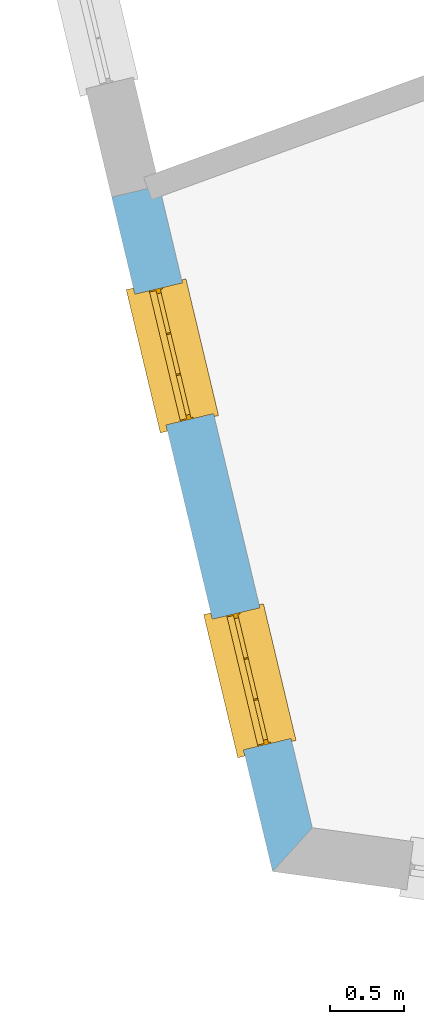
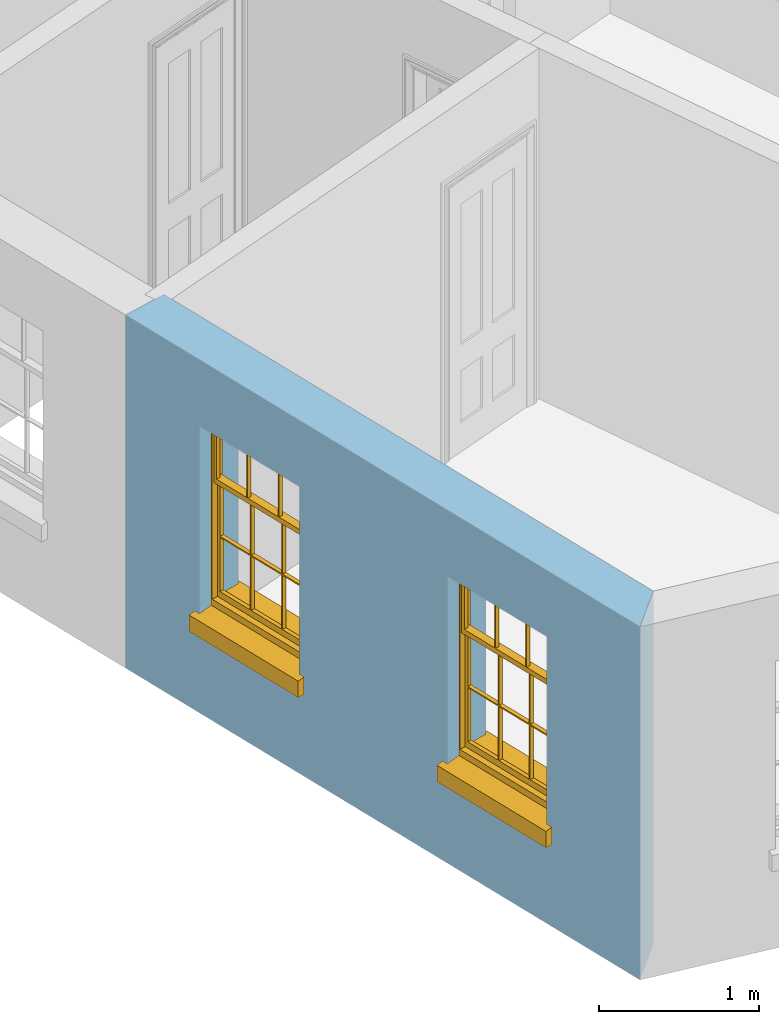
# One storey, part 2 of 12: 2 windows, 2 openings, plus 1 element that does not belong to this part.
"""IFC2X3 building model written with IfcOpenShell, lengths in metres."""

from ifc_helpers import new_model, si_unit, frame, origin, place, context, subcontext, project, spatial, polyline, outline, extrude, faceted_brep, material, layer, layer_set, layer_usage, element, fill, save


model = new_model("IFC2X3")

# Units and contexts
model_context = context("Model", 3, world=origin())
body_context = subcontext(model_context, "Body", "Model", "MODEL_VIEW")
ifc_project = project(units=[si_unit("PLANEANGLEUNIT", "RADIAN"), si_unit("MASSUNIT", "GRAM", prefix="KILO"), si_unit("FORCEUNIT", "NEWTON", prefix="KILO"), si_unit("LENGTHUNIT", "METRE")], contexts=[model_context])

# Site, building, storey
site_placement = place(None, origin())
site = spatial("IfcSite", under=ifc_project, at=site_placement, CompositionType="ELEMENT")
building_placement = place(None, origin())
building = spatial("IfcBuilding", under=site, at=building_placement, Name="Building plot-12", CompositionType="ELEMENT")
storey_placement = place(None, frame((0.0, 0.0, 6.45)))
storey = spatial("IfcBuildingStorey", under=building, at=storey_placement, Name="Floor 1", CompositionType="ELEMENT", Elevation=6.45)

# Wall, openings, windows
ifc_material = material(Name="Masonry")
ifc_layer = layer(ifc_material, 0.33, ventilated=False)
ifc_layer_set = layer_set([ifc_layer], Name="My Wall")
ifc_layer_usage = layer_usage(ifc_layer_set, "AXIS2", "NEGATIVE", 0.08)
wall_placement = place(storey_placement, origin())
wall = element("IfcWallStandardCase", 1, at=wall_placement, inside=storey, material=ifc_layer_usage, Name="exterior", context=body_context, shape_type="SweptSolid", body=[
    extrude(outline(polyline([(54.7536599454522, 36.2256595733621), (54.4326600181389, 36.1491151636064), (55.519891283054, 31.5896553921575), (55.7885191142734, 31.8858296755126), (54.7536599454522, 36.2256595733621)])), origin(), (0.0, 0.0, 1.0), 2.7),
])
opening_1_placement = place(storey_placement, frame((0.0, 0.0, 0.75)))
opening_1 = element("IfcOpeningElement", 2, at=opening_1_placement, cuts=wall, Name="Opening", ObjectType="Opening", context=body_context, shape_type="SweptSolid", body=[
    extrude(outline(polyline([(54.5890103724139, 35.4934375965852), (54.8000873811343, 34.6082559788424), (55.1210873084476, 34.6848003885981), (54.9100102997273, 35.5699820063409), (54.5890103724139, 35.4934375965852)])), origin(), (0.0, 0.0, 1.0), 1.445),
])
opening_2_placement = place(storey_placement, frame((0.0, 0.0, 0.75)))
opening_2 = element("IfcOpeningElement", 3, at=opening_2_placement, cuts=wall, Name="Opening", ObjectType="Opening", context=body_context, shape_type="SweptSolid", body=[
    extrude(outline(polyline([(55.1127880896844, 33.2969008447999), (55.3238650984048, 32.4117192270571), (55.6448650257181, 32.4882636368128), (55.4337880169978, 33.3734452545556), (55.1127880896844, 33.2969008447999)])), origin(), (0.0, 0.0, 1.0), 1.445),
])
window_1_placement = place(storey_placement, frame((54.8321921355301, 35.551425785794, 0.75), z_axis=(0.0, 0.0, 1.0), x_axis=(0.211077008720331, -0.885181617742752, 0.0)))
window_1 = element("IfcWindow", 4, at=window_1_placement, inside=storey, Name="living outside window", OverallHeight=1.445, OverallWidth=0.91, context=body_context, shape_type="Brep", held_by="IfcProductRepresentation", body=[
    faceted_brep([(0.876875, -0.105, 0.999097), (0.876875, -0.105, 1.411875), (0.9, -0.105, 1.435), (0.033125, -0.105, 1.411875), (0.033125, -0.105, 0.999097), (0.01, -0.105, 1.435), (0.033125, -0.135, 1.411875), (0.01, -0.135, 1.435), (0.033125, -0.135, 0.999097), (0.876875, -0.135, 1.411875), (0.876875, -0.135, 0.999097), (0.9, -0.135, 1.435), (0.033125, -0.105, 0.960972), (0.01, -0.105, 0.960972), (0.033125, -0.105, 0.548195), (0.876875, -0.105, 0.960972), (0.876875, -0.105, 0.548195), (0.9, -0.105, 0.960972), (0.876875, -0.105, 0.538195), (0.876875, -0.105, 0.125417), (0.9, -0.105, 0.077167), (0.033125, -0.105, 0.125417), (0.033125, -0.105, 0.538195), (0.01, -0.105, 0.077167), (0.9, -0.135, 0.960972), (0.01, -0.135, 0.960972), (-0.0425, -0.25, 0.01), (-0.0425, -0.3, 0.001667), (0.0, -0.25, 0.01), (0.9525, -0.25, 0.01), (0.91, -0.25, 0.01), (0.9525, -0.3, 0.001667), (-0.02, 0.08, 0.077167), (0.0, 0.08, 0.077167), (-0.02, 0.11, 0.077167), (0.0, -0.06, 0.077167), (0.01, -0.06, 0.077167), (0.91, -0.06, 0.077167), (0.91, 0.08, 0.077167), (0.9, -0.06, 0.077167), (0.93, 0.08, 0.077167), (0.93, 0.11, 0.077167), (0.01, -0.105, 0.999097), (0.01, -0.075, 0.999097), (0.9, -0.105, 0.999097), (0.9, -0.075, 0.999097), (0.876875, -0.075, 0.125417), (0.876875, -0.075, 0.538195), (0.9, -0.075, 0.077167), (0.876875, -0.075, 0.548195), (0.876875, -0.075, 0.960972), (0.033125, -0.075, 0.125417), (0.01, -0.075, 0.077167), (0.033125, -0.075, 0.538195), (0.033125, -0.075, 0.960972), (0.033125, -0.075, 0.548195), (-0.02, 0.08, 0.052167), (-0.02, 0.11, 0.052167), (0.93, 0.11, 0.052167), (0.93, 0.08, 0.052167), (0.91, 0.08, 0.052167), (0.0, 0.08, 0.052167), (0.91, -0.15, 0.026667), (0.0, -0.15, 0.026667), (-0.0425, -0.3, -0.123333), (0.9525, -0.3, -0.123333), (-0.0425, -0.25, -0.123333), (0.9525, -0.25, -0.123333), (0.01, -0.06, 1.435), (0.9, -0.06, 1.435), (0.0, -0.06, 1.445), (0.91, -0.06, 1.445), (0.01, -0.15, 0.077167), (0.9, -0.15, 0.077167), (0.592292, -0.105, 0.125417), (0.592292, -0.075, 0.125417), (0.317708, -0.075, 0.125417), (0.317708, -0.105, 0.125417), (0.592292, -0.105, 0.548195), (0.317708, -0.105, 0.548195), (0.317708, -0.105, 0.538195), (0.592292, -0.105, 0.538195), (0.592292, -0.075, 0.548195), (0.317708, -0.075, 0.548195), (0.602292, -0.075, 0.548195), (0.602292, -0.105, 0.548195), (0.317708, -0.075, 0.538195), (0.307708, -0.075, 0.125417), (0.307708, -0.075, 0.538195), (0.602292, -0.075, 0.538195), (0.602292, -0.075, 0.125417), (0.592292, -0.075, 0.538195), (0.307708, -0.075, 0.548195), (0.317708, -0.075, 0.960972), (0.307708, -0.075, 0.960972), (0.602292, -0.075, 0.960972), (0.592292, -0.075, 0.960972), (0.307708, -0.105, 0.538195), (0.307708, -0.105, 0.125417), (0.307708, -0.105, 0.548195), (0.307708, -0.105, 0.960972), (0.592292, -0.105, 0.960972), (0.317708, -0.105, 0.960972), (0.602292, -0.105, 0.960972), (0.602292, -0.105, 0.538195), (0.602292, -0.105, 0.125417), (0.317708, -0.135, 1.411875), (0.307708, -0.135, 1.411875), (0.307708, -0.135, 0.999097), (0.317708, -0.135, 0.999097), (0.602292, -0.135, 1.411875), (0.592292, -0.135, 1.411875), (0.592292, -0.135, 0.999097), (0.602292, -0.135, 0.999097), (0.317708, -0.105, 0.999097), (0.307708, -0.105, 0.999097), (0.307708, -0.105, 1.411875), (0.317708, -0.105, 1.411875), (0.602292, -0.105, 0.999097), (0.592292, -0.105, 0.999097), (0.592292, -0.105, 1.411875), (0.602292, -0.105, 1.411875), (0.91, -0.15, 1.445), (0.9, -0.15, 1.435), (0.01, -0.15, 1.435), (0.0, -0.15, 1.445), (0.91, -0.25, 0.0), (0.0, -0.25, 0.0), (0.91, 0.08, 0.0), (0.0, 0.08, 0.0)], [[[0, 1, 2]], [[3, 4, 5]], [[6, 7, 8]], [[9, 10, 11]], [[12, 13, 14]], [[15, 16, 17]], [[18, 19, 20]], [[21, 22, 23]], [[24, 15, 17]], [[13, 12, 25]], [[26, 27, 28]], [[29, 30, 31]], [[32, 33, 34]], [[35, 36, 33]], [[37, 38, 39]], [[40, 41, 38]], [[42, 4, 43]], [[44, 45, 0]], [[46, 47, 48]], [[49, 50, 45]], [[51, 52, 53]], [[54, 55, 43]], [[38, 33, 36, 39]], [[41, 34, 33, 38]], [[56, 32, 34, 57]], [[57, 34, 41, 58]], [[58, 41, 40, 59]], [[57, 58, 60, 61]], [[52, 48, 39, 36]], [[62, 63, 28, 30]], [[27, 31, 30, 28]], [[27, 64, 65, 31]], [[66, 67, 65, 64]], [[2, 5, 68, 69]], [[68, 70, 71, 69]], [[20, 23, 72, 73]], [[73, 72, 63, 62]], [[74, 75, 76, 77]], [[78, 79, 80, 81]], [[78, 82, 83, 79]], [[16, 49, 84, 85]], [[86, 76, 87, 88]], [[89, 90, 75, 91]], [[92, 88, 53, 55]], [[82, 91, 86, 83]], [[93, 83, 92, 94]], [[95, 84, 82, 96]], [[89, 84, 49, 47]], [[97, 88, 87, 98]], [[22, 53, 88, 97]], [[81, 91, 75, 74]], [[80, 86, 91, 81]], [[77, 76, 86, 80]], [[99, 92, 55, 14]], [[100, 94, 92, 99]], [[101, 96, 82, 78]], [[79, 83, 93, 102]], [[85, 84, 95, 103]], [[104, 89, 47, 18]], [[105, 90, 89, 104]], [[104, 18, 16, 85]], [[80, 97, 98, 77]], [[104, 81, 74, 105]], [[103, 101, 78, 85]], [[99, 14, 22, 97]], [[102, 100, 99, 79]], [[106, 107, 108, 109]], [[110, 111, 112, 113]], [[114, 115, 116, 117]], [[118, 119, 120, 121]], [[107, 116, 115, 108]], [[111, 120, 119, 112]], [[109, 114, 117, 106]], [[113, 118, 121, 110]], [[85, 78, 81, 104]], [[84, 89, 91, 82]], [[83, 86, 88, 92]], [[79, 99, 97, 80]], [[109, 112, 119, 114]], [[102, 93, 96, 101]], [[106, 117, 120, 111]], [[98, 87, 51, 21]], [[6, 3, 116, 107]], [[110, 121, 1, 9]], [[19, 46, 90, 105]], [[26, 66, 64, 27]], [[29, 31, 65, 67]], [[25, 24, 112, 109]], [[11, 7, 106, 111]], [[75, 48, 52, 76]], [[43, 45, 96, 93]], [[45, 43, 114, 119]], [[5, 2, 120, 117]], [[24, 25, 102, 101]], [[42, 5, 4]], [[2, 44, 0]], [[49, 45, 48, 47]], [[52, 43, 55, 53]], [[14, 13, 23, 22]], [[20, 17, 16, 18]], [[24, 11, 10]], [[25, 8, 7]], [[8, 4, 3, 6]], [[9, 1, 0, 10]], [[15, 50, 49, 16]], [[18, 47, 46, 19]], [[21, 51, 53, 22]], [[14, 55, 54, 12]], [[44, 2, 69, 45]], [[68, 5, 42, 43]], [[36, 35, 70, 68]], [[39, 69, 71, 37]], [[62, 122, 123, 73]], [[63, 72, 124, 125]], [[8, 108, 115, 4]], [[113, 10, 0, 118]], [[94, 100, 12, 54]], [[17, 20, 73, 24]], [[72, 23, 13, 25]], [[52, 36, 68, 43]], [[69, 39, 48, 45]], [[11, 24, 73, 123]], [[7, 124, 72, 25]], [[23, 77, 98]], [[98, 21, 23]], [[105, 74, 20]], [[20, 19, 105]], [[20, 74, 77, 23]], [[113, 112, 24]], [[24, 10, 113]], [[25, 109, 108]], [[108, 8, 25]], [[110, 9, 11]], [[11, 111, 110]], [[7, 6, 107]], [[107, 106, 7]], [[5, 117, 116]], [[116, 3, 5]], [[121, 120, 2]], [[2, 1, 121]], [[11, 123, 124, 7]], [[122, 125, 124, 123]], [[43, 93, 94]], [[94, 54, 43]], [[96, 45, 95]], [[50, 95, 45]], [[15, 103, 95, 50]], [[48, 75, 90]], [[90, 46, 48]], [[87, 76, 52]], [[52, 51, 87]], [[103, 15, 24]], [[24, 101, 103]], [[100, 102, 25]], [[25, 12, 100]], [[115, 114, 43]], [[43, 4, 115]], [[118, 0, 45]], [[45, 119, 118]], [[71, 70, 125, 122]], [[70, 35, 63, 125]], [[122, 62, 37, 71]], [[126, 67, 66, 127]], [[60, 58, 59]], [[38, 60, 59, 40]], [[61, 56, 57]], [[32, 56, 61, 33]], [[61, 60, 128, 129]], [[62, 60, 38, 37]], [[126, 128, 60, 62]], [[33, 61, 63, 35]], [[61, 129, 127, 63]], [[128, 126, 127, 129]], [[28, 127, 66, 26]], [[63, 127, 28]], [[29, 67, 126, 30]], [[30, 126, 62]]]),
])
fill(opening_1, window_1)
window_2_placement = place(storey_placement, frame((55.3559698528006, 33.3548890340087, 0.75), z_axis=(0.0, 0.0, 1.0), x_axis=(0.211077008720331, -0.885181617742752, 0.0)))
window_2 = element("IfcWindow", 5, at=window_2_placement, inside=storey, Name="living outside window", OverallHeight=1.445, OverallWidth=0.91, context=body_context, shape_type="Brep", held_by="IfcProductRepresentation", body=[
    faceted_brep([(0.876875, -0.105, 0.999097), (0.876875, -0.105, 1.411875), (0.9, -0.105, 1.435), (0.033125, -0.105, 1.411875), (0.033125, -0.105, 0.999097), (0.01, -0.105, 1.435), (0.033125, -0.135, 1.411875), (0.01, -0.135, 1.435), (0.033125, -0.135, 0.999097), (0.876875, -0.135, 1.411875), (0.876875, -0.135, 0.999097), (0.9, -0.135, 1.435), (0.033125, -0.105, 0.960972), (0.01, -0.105, 0.960972), (0.033125, -0.105, 0.548195), (0.876875, -0.105, 0.960972), (0.876875, -0.105, 0.548195), (0.9, -0.105, 0.960972), (0.876875, -0.105, 0.538195), (0.876875, -0.105, 0.125417), (0.9, -0.105, 0.077167), (0.033125, -0.105, 0.125417), (0.033125, -0.105, 0.538195), (0.01, -0.105, 0.077167), (0.9, -0.135, 0.960972), (0.01, -0.135, 0.960972), (-0.0425, -0.25, 0.01), (-0.0425, -0.3, 0.001667), (0.0, -0.25, 0.01), (0.9525, -0.25, 0.01), (0.91, -0.25, 0.01), (0.9525, -0.3, 0.001667), (-0.02, 0.08, 0.077167), (0.0, 0.08, 0.077167), (-0.02, 0.11, 0.077167), (0.0, -0.06, 0.077167), (0.01, -0.06, 0.077167), (0.91, -0.06, 0.077167), (0.91, 0.08, 0.077167), (0.9, -0.06, 0.077167), (0.93, 0.08, 0.077167), (0.93, 0.11, 0.077167), (0.01, -0.105, 0.999097), (0.01, -0.075, 0.999097), (0.9, -0.105, 0.999097), (0.9, -0.075, 0.999097), (0.876875, -0.075, 0.125417), (0.876875, -0.075, 0.538195), (0.9, -0.075, 0.077167), (0.876875, -0.075, 0.548195), (0.876875, -0.075, 0.960972), (0.033125, -0.075, 0.125417), (0.01, -0.075, 0.077167), (0.033125, -0.075, 0.538195), (0.033125, -0.075, 0.960972), (0.033125, -0.075, 0.548195), (-0.02, 0.08, 0.052167), (-0.02, 0.11, 0.052167), (0.93, 0.11, 0.052167), (0.93, 0.08, 0.052167), (0.91, 0.08, 0.052167), (0.0, 0.08, 0.052167), (0.91, -0.15, 0.026667), (0.0, -0.15, 0.026667), (-0.0425, -0.3, -0.123333), (0.9525, -0.3, -0.123333), (-0.0425, -0.25, -0.123333), (0.9525, -0.25, -0.123333), (0.01, -0.06, 1.435), (0.9, -0.06, 1.435), (0.0, -0.06, 1.445), (0.91, -0.06, 1.445), (0.01, -0.15, 0.077167), (0.9, -0.15, 0.077167), (0.592292, -0.105, 0.125417), (0.592292, -0.075, 0.125417), (0.317708, -0.075, 0.125417), (0.317708, -0.105, 0.125417), (0.592292, -0.105, 0.548195), (0.317708, -0.105, 0.548195), (0.317708, -0.105, 0.538195), (0.592292, -0.105, 0.538195), (0.592292, -0.075, 0.548195), (0.317708, -0.075, 0.548195), (0.602292, -0.075, 0.548195), (0.602292, -0.105, 0.548195), (0.317708, -0.075, 0.538195), (0.307708, -0.075, 0.125417), (0.307708, -0.075, 0.538195), (0.602292, -0.075, 0.538195), (0.602292, -0.075, 0.125417), (0.592292, -0.075, 0.538195), (0.307708, -0.075, 0.548195), (0.317708, -0.075, 0.960972), (0.307708, -0.075, 0.960972), (0.602292, -0.075, 0.960972), (0.592292, -0.075, 0.960972), (0.307708, -0.105, 0.538195), (0.307708, -0.105, 0.125417), (0.307708, -0.105, 0.548195), (0.307708, -0.105, 0.960972), (0.592292, -0.105, 0.960972), (0.317708, -0.105, 0.960972), (0.602292, -0.105, 0.960972), (0.602292, -0.105, 0.538195), (0.602292, -0.105, 0.125417), (0.317708, -0.135, 1.411875), (0.307708, -0.135, 1.411875), (0.307708, -0.135, 0.999097), (0.317708, -0.135, 0.999097), (0.602292, -0.135, 1.411875), (0.592292, -0.135, 1.411875), (0.592292, -0.135, 0.999097), (0.602292, -0.135, 0.999097), (0.317708, -0.105, 0.999097), (0.307708, -0.105, 0.999097), (0.307708, -0.105, 1.411875), (0.317708, -0.105, 1.411875), (0.602292, -0.105, 0.999097), (0.592292, -0.105, 0.999097), (0.592292, -0.105, 1.411875), (0.602292, -0.105, 1.411875), (0.91, -0.15, 1.445), (0.9, -0.15, 1.435), (0.01, -0.15, 1.435), (0.0, -0.15, 1.445), (0.91, -0.25, 0.0), (0.0, -0.25, 0.0), (0.91, 0.08, 0.0), (0.0, 0.08, 0.0)], [[[0, 1, 2]], [[3, 4, 5]], [[6, 7, 8]], [[9, 10, 11]], [[12, 13, 14]], [[15, 16, 17]], [[18, 19, 20]], [[21, 22, 23]], [[24, 15, 17]], [[13, 12, 25]], [[26, 27, 28]], [[29, 30, 31]], [[32, 33, 34]], [[35, 36, 33]], [[37, 38, 39]], [[40, 41, 38]], [[42, 4, 43]], [[44, 45, 0]], [[46, 47, 48]], [[49, 50, 45]], [[51, 52, 53]], [[54, 55, 43]], [[38, 33, 36, 39]], [[41, 34, 33, 38]], [[56, 32, 34, 57]], [[57, 34, 41, 58]], [[58, 41, 40, 59]], [[57, 58, 60, 61]], [[52, 48, 39, 36]], [[62, 63, 28, 30]], [[27, 31, 30, 28]], [[27, 64, 65, 31]], [[66, 67, 65, 64]], [[2, 5, 68, 69]], [[68, 70, 71, 69]], [[20, 23, 72, 73]], [[73, 72, 63, 62]], [[74, 75, 76, 77]], [[78, 79, 80, 81]], [[78, 82, 83, 79]], [[16, 49, 84, 85]], [[86, 76, 87, 88]], [[89, 90, 75, 91]], [[92, 88, 53, 55]], [[82, 91, 86, 83]], [[93, 83, 92, 94]], [[95, 84, 82, 96]], [[89, 84, 49, 47]], [[97, 88, 87, 98]], [[22, 53, 88, 97]], [[81, 91, 75, 74]], [[80, 86, 91, 81]], [[77, 76, 86, 80]], [[99, 92, 55, 14]], [[100, 94, 92, 99]], [[101, 96, 82, 78]], [[79, 83, 93, 102]], [[85, 84, 95, 103]], [[104, 89, 47, 18]], [[105, 90, 89, 104]], [[104, 18, 16, 85]], [[80, 97, 98, 77]], [[104, 81, 74, 105]], [[103, 101, 78, 85]], [[99, 14, 22, 97]], [[102, 100, 99, 79]], [[106, 107, 108, 109]], [[110, 111, 112, 113]], [[114, 115, 116, 117]], [[118, 119, 120, 121]], [[107, 116, 115, 108]], [[111, 120, 119, 112]], [[109, 114, 117, 106]], [[113, 118, 121, 110]], [[85, 78, 81, 104]], [[84, 89, 91, 82]], [[83, 86, 88, 92]], [[79, 99, 97, 80]], [[109, 112, 119, 114]], [[102, 93, 96, 101]], [[106, 117, 120, 111]], [[98, 87, 51, 21]], [[6, 3, 116, 107]], [[110, 121, 1, 9]], [[19, 46, 90, 105]], [[26, 66, 64, 27]], [[29, 31, 65, 67]], [[25, 24, 112, 109]], [[11, 7, 106, 111]], [[75, 48, 52, 76]], [[43, 45, 96, 93]], [[45, 43, 114, 119]], [[5, 2, 120, 117]], [[24, 25, 102, 101]], [[42, 5, 4]], [[2, 44, 0]], [[49, 45, 48, 47]], [[52, 43, 55, 53]], [[14, 13, 23, 22]], [[20, 17, 16, 18]], [[24, 11, 10]], [[25, 8, 7]], [[8, 4, 3, 6]], [[9, 1, 0, 10]], [[15, 50, 49, 16]], [[18, 47, 46, 19]], [[21, 51, 53, 22]], [[14, 55, 54, 12]], [[44, 2, 69, 45]], [[68, 5, 42, 43]], [[36, 35, 70, 68]], [[39, 69, 71, 37]], [[62, 122, 123, 73]], [[63, 72, 124, 125]], [[8, 108, 115, 4]], [[113, 10, 0, 118]], [[94, 100, 12, 54]], [[17, 20, 73, 24]], [[72, 23, 13, 25]], [[52, 36, 68, 43]], [[69, 39, 48, 45]], [[11, 24, 73, 123]], [[7, 124, 72, 25]], [[23, 77, 98]], [[98, 21, 23]], [[105, 74, 20]], [[20, 19, 105]], [[20, 74, 77, 23]], [[113, 112, 24]], [[24, 10, 113]], [[25, 109, 108]], [[108, 8, 25]], [[110, 9, 11]], [[11, 111, 110]], [[7, 6, 107]], [[107, 106, 7]], [[5, 117, 116]], [[116, 3, 5]], [[121, 120, 2]], [[2, 1, 121]], [[11, 123, 124, 7]], [[122, 125, 124, 123]], [[43, 93, 94]], [[94, 54, 43]], [[96, 45, 95]], [[50, 95, 45]], [[15, 103, 95, 50]], [[48, 75, 90]], [[90, 46, 48]], [[87, 76, 52]], [[52, 51, 87]], [[103, 15, 24]], [[24, 101, 103]], [[100, 102, 25]], [[25, 12, 100]], [[115, 114, 43]], [[43, 4, 115]], [[118, 0, 45]], [[45, 119, 118]], [[71, 70, 125, 122]], [[70, 35, 63, 125]], [[122, 62, 37, 71]], [[126, 67, 66, 127]], [[60, 58, 59]], [[38, 60, 59, 40]], [[61, 56, 57]], [[32, 56, 61, 33]], [[61, 60, 128, 129]], [[62, 60, 38, 37]], [[126, 128, 60, 62]], [[33, 61, 63, 35]], [[61, 129, 127, 63]], [[128, 126, 127, 129]], [[28, 127, 66, 26]], [[63, 127, 28]], [[29, 67, 126, 30]], [[30, 126, 62]]]),
])
fill(opening_2, window_2)

save(model, "model.ifc")
